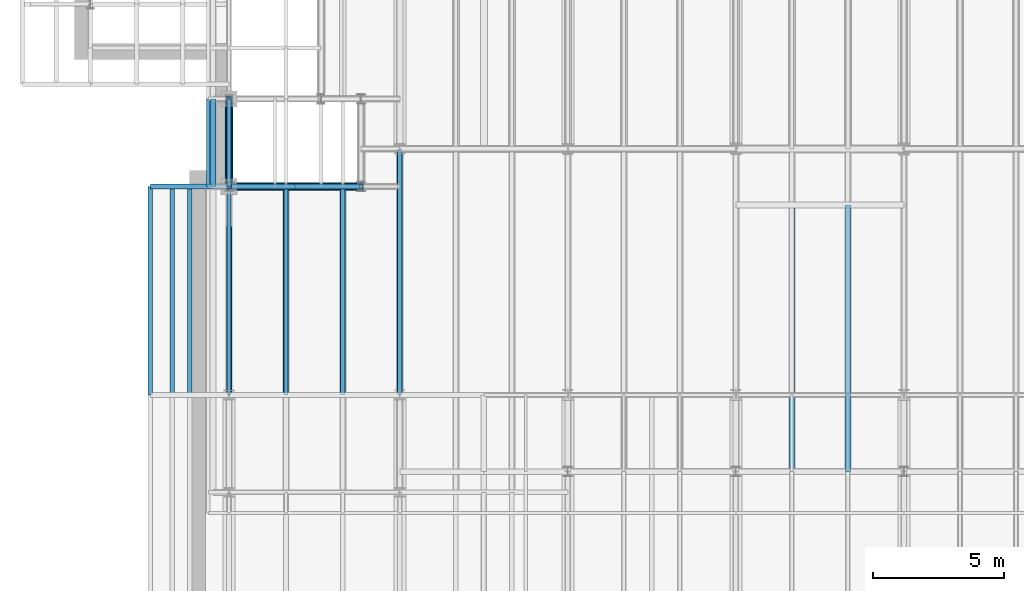
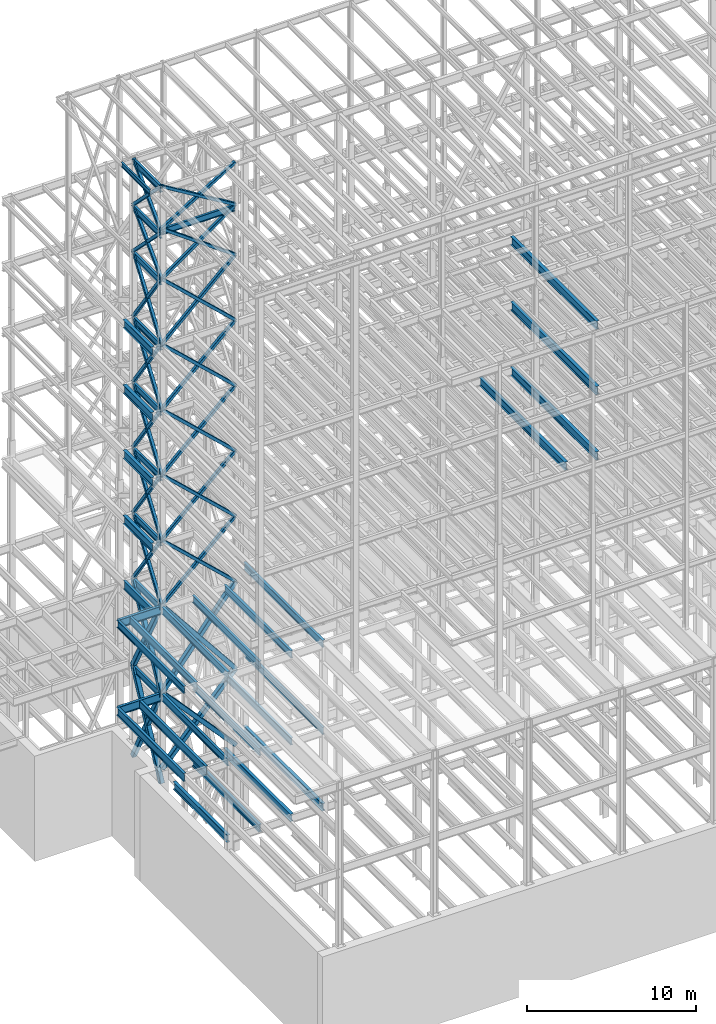
# One storey, part 124 of 150: 74 beams.
"""IFC2X3 building model written with IfcOpenShell, lengths in millimetres."""

from ifc_helpers import new_model, si_unit, frame, origin_with_axes, origin_2d_with_axis, place, context, subcontext, project, spatial, hollow_rectangle, i_section, extrude, material, type_object, element, save


model = new_model("IFC2X3")

# Units and contexts
model_context = context("Model", 3, precision=1e-05, world=origin_with_axes())
body_context = subcontext(model_context, "Body", "Model", "MODEL_VIEW")
ifc_project = project(units=[si_unit("LENGTHUNIT", "METRE", prefix="MILLI"), si_unit("AREAUNIT", "SQUARE_METRE"), si_unit("VOLUMEUNIT", "CUBIC_METRE"), si_unit("MASSUNIT", "GRAM", prefix="KILO"), si_unit("TIMEUNIT", "SECOND"), si_unit("PLANEANGLEUNIT", "RADIAN"), si_unit("SOLIDANGLEUNIT", "STERADIAN"), si_unit("THERMODYNAMICTEMPERATUREUNIT", "DEGREE_CELSIUS"), si_unit("LUMINOUSINTENSITYUNIT", "LUMEN")], contexts=[model_context])

# Site, building, storey
site_placement = place(None, origin_with_axes())
site = spatial("IfcSite", under=ifc_project, at=site_placement, CompositionType="ELEMENT")
building_placement = place(site_placement, origin_with_axes())
building = spatial("IfcBuilding", under=site, at=building_placement, Name="Undefined", CompositionType="ELEMENT")
storey_placement = place(building_placement, origin_with_axes())
storey = spatial("IfcBuildingStorey", under=building, at=storey_placement, Name="Undefined", CompositionType="ELEMENT", Elevation=0.0)

# Beams
ifc_material_1 = material()
beam_type_1 = type_object("IfcBeamType", Name="HSS8X8X3/8", PredefinedType="NOTDEFINED")
beam_1_placement = place(storey_placement, frame((10312.3992353852, 21043.9001130334, 62839.59932357), z_axis=(0.521450134847236, 0.0, 0.853281757022731), x_axis=(-0.853281757022731, 0.0, 0.521450134847236)))
element("IfcBeam", 1, at=beam_1_placement, inside=storey, type_object=beam_type_1, material=ifc_material_1, Name="BEAM", ObjectType="HSS8X8X3/8", context=body_context, shape_type="SweptSolid", body=[
    extrude(hollow_rectangle(XDim=203.2, YDim=203.2, WallThickness=9.525, InnerFilletRadius=9.5249, OuterFilletRadius=19.0499, at=origin_2d_with_axis()), frame((5893.94915716689, 0.0, 0.0), z_axis=(-1.0, 0.0, 0.0), x_axis=(0.0, -1.0, 0.0)), (0.0, 0.0, 1.0), 5893.94915716689),
])
beam_2_placement = place(storey_placement, frame((5283.2, 21043.9, 62839.6), z_axis=(-0.521450017543864, 0.0, 0.853281828708138), x_axis=(0.853281828708139, 0.0, 0.521450017543863)))
element("IfcBeam", 2, at=beam_2_placement, inside=storey, type_object=beam_type_1, material=ifc_material_1, Name="BEAM", ObjectType="HSS8X8X3/8", context=body_context, shape_type="SweptSolid", body=[
    extrude(hollow_rectangle(XDim=203.2, YDim=203.2, WallThickness=9.525, InnerFilletRadius=9.5249, OuterFilletRadius=19.0499, at=origin_2d_with_axis()), frame((5893.94902774016, 0.0, -3.27179895828209e-13), z_axis=(-1.0, 0.0, 0.0), x_axis=(0.0, -1.0, 0.0)), (0.0, 0.0, 1.0), 5893.94902774016),
])
beam_3_placement = place(storey_placement, frame((10312.3992353852, 21043.9001130334, 59207.39932357), z_axis=(0.585490645122251, 0.0, 0.810679162476951), x_axis=(-0.81067916247695, 0.0, 0.585490645122252)))
element("IfcBeam", 3, at=beam_3_placement, inside=storey, type_object=beam_type_1, material=ifc_material_1, Name="BEAM", ObjectType="HSS8X8X3/8", context=body_context, shape_type="SweptSolid", body=[
    extrude(hollow_rectangle(XDim=203.2, YDim=203.2, WallThickness=9.525, InnerFilletRadius=9.5249, OuterFilletRadius=19.0499, at=origin_2d_with_axis()), frame((6203.68654134889, 3.63797880709171e-12, 6.88747563576274e-13), z_axis=(-1.0, 0.0, 0.0), x_axis=(0.0, -1.0, 0.0)), (0.0, 0.0, 1.0), 6203.68654134889),
])
beam_4_placement = place(storey_placement, frame((5283.2, 21043.9, 59207.4), z_axis=(-0.585490531937664, 0.0, 0.810679244221382), x_axis=(0.810679244221382, 0.0, 0.585490531937663)))
element("IfcBeam", 4, at=beam_4_placement, inside=storey, type_object=beam_type_1, material=ifc_material_1, Name="BEAM", ObjectType="HSS8X8X3/8", context=body_context, shape_type="SweptSolid", body=[
    extrude(hollow_rectangle(XDim=203.2, YDim=203.2, WallThickness=9.525, InnerFilletRadius=9.5249, OuterFilletRadius=19.0499, at=origin_2d_with_axis()), frame((6203.68635746518, 0.0, 0.0), z_axis=(-1.0, 0.0, 0.0), x_axis=(0.0, -1.0, 0.0)), (0.0, 0.0, 1.0), 6203.68635746518),
])
beam_5_placement = place(storey_placement, frame((10312.3992353852, 21043.9001130334, 54482.99932357), z_axis=(0.684675567907954, 0.0, 0.728847972289092), x_axis=(-0.728847972289091, 0.0, 0.684675567907954)))
element("IfcBeam", 5, at=beam_5_placement, inside=storey, type_object=beam_type_1, material=ifc_material_1, Name="BEAM", ObjectType="HSS8X8X3/8", context=body_context, shape_type="SweptSolid", body=[
    extrude(hollow_rectangle(XDim=203.2, YDim=203.2, WallThickness=9.525, InnerFilletRadius=9.5249, OuterFilletRadius=19.0499, at=origin_2d_with_axis()), frame((6900.20338110779, 0.0, 7.66076466830223e-13), z_axis=(-1.0, 0.0, 0.0), x_axis=(0.0, -1.0, 0.0)), (0.0, 0.0, 1.0), 6900.20338110779),
])
beam_6_placement = place(storey_placement, frame((5283.2, 21043.9, 54483.0), z_axis=(-0.684675464883562, 0.0, 0.728848069069596), x_axis=(0.728848069069596, 0.0, 0.684675464883561)))
element("IfcBeam", 6, at=beam_6_placement, inside=storey, type_object=beam_type_1, material=ifc_material_1, Name="BEAM", ObjectType="HSS8X8X3/8", context=body_context, shape_type="SweptSolid", body=[
    extrude(hollow_rectangle(XDim=203.2, YDim=203.2, WallThickness=9.525, InnerFilletRadius=9.5249, OuterFilletRadius=19.0499, at=origin_2d_with_axis()), frame((6900.20310870845, 0.0, 0.0), z_axis=(-1.0, 0.0, 0.0), x_axis=(0.0, -1.0, 0.0)), (0.0, 0.0, 1.0), 6900.20310870845),
])
beam_7_placement = place(storey_placement, frame((10312.39949708, 21043.9001130334, 40309.8), z_axis=(0.684675567907954, 0.0, 0.728847972289092), x_axis=(-0.728847972289091, 0.0, 0.684675567907954)))
element("IfcBeam", 7, at=beam_7_placement, inside=storey, type_object=beam_type_1, material=ifc_material_1, Name="BEAM", ObjectType="HSS8X8X3/8", context=body_context, shape_type="SweptSolid", body=[
    extrude(hollow_rectangle(XDim=203.2, YDim=203.2, WallThickness=9.525, InnerFilletRadius=9.5249, OuterFilletRadius=19.0499, at=origin_2d_with_axis()), frame((6900.20310870845, 0.0, 0.0), z_axis=(-1.0, 0.0, 0.0), x_axis=(0.0, -1.0, 0.0)), (0.0, 0.0, 1.0), 6900.20310870844),
])
beam_8_placement = place(storey_placement, frame((5283.2, 21043.9, 40309.8), z_axis=(-0.684675464883562, 0.0, 0.728848069069596), x_axis=(0.728848069069596, 0.0, 0.684675464883561)))
element("IfcBeam", 8, at=beam_8_placement, inside=storey, type_object=beam_type_1, material=ifc_material_1, Name="BEAM", ObjectType="HSS8X8X3/8", context=body_context, shape_type="SweptSolid", body=[
    extrude(hollow_rectangle(XDim=203.2, YDim=203.2, WallThickness=9.525, InnerFilletRadius=9.5249, OuterFilletRadius=19.0499, at=origin_2d_with_axis()), frame((6900.20310870845, 0.0, 0.0), z_axis=(-1.0, 0.0, 0.0), x_axis=(0.0, -1.0, 0.0)), (0.0, 0.0, 1.0), 6900.20308523769),
])
for number, where, z_axis, x_axis, name in (
    (9, (10312.39949708, 21043.9001130334, 35585.4), (0.684675567907954, 0.0, 0.728847972289092), (-0.728847972289091, 0.0, 0.684675567907954), "BEAM"),
    (10, (5283.2, 21043.9, 35585.4), (-0.684675464883562, 0.0, 0.728848069069596), (0.728848069069596, 0.0, 0.684675464883561), "BEAM"),
):
    element("IfcBeam", number, at=place(storey_placement, frame(where, z_axis=z_axis, x_axis=x_axis)), inside=storey, type_object=beam_type_1, material=ifc_material_1, Name=name, ObjectType="HSS8X8X3/8", context=body_context, shape_type="SweptSolid", body=[
        extrude(hollow_rectangle(XDim=203.2, YDim=203.2, WallThickness=9.525, InnerFilletRadius=9.5249, OuterFilletRadius=19.0499, at=origin_2d_with_axis()), frame((6900.20310870845, 0.0, 0.0), z_axis=(-1.0, 0.0, 0.0), x_axis=(0.0, -1.0, 0.0)), (0.0, 0.0, 1.0), 6900.20310870845),
    ])
beam_9_placement = place(storey_placement, frame((5283.2, 24383.9997539549, 62560.1996954019), z_axis=(0.0, 0.708447258296166, 0.705763758075353), x_axis=(0.0, -0.705763758075351, 0.708447258296168)))
element("IfcBeam", 11, at=beam_9_placement, inside=storey, type_object=beam_type_1, material=ifc_material_1, Name="BEAM", ObjectType="HSS8X8X3/8", context=body_context, shape_type="SweptSolid", body=[
    extrude(hollow_rectangle(XDim=203.2, YDim=203.2, WallThickness=9.525, InnerFilletRadius=9.5249, OuterFilletRadius=19.0499, at=origin_2d_with_axis()), frame((4732.60349596287, 0.0, 0.0), z_axis=(-1.0, 0.0, 0.0), x_axis=(0.0, -1.0, 0.0)), (0.0, 0.0, 1.0), 4732.60353810488),
])
beam_10_placement = place(storey_placement, frame((5283.2, 21043.9002460451, 62560.1996954019), z_axis=(0.0, -0.708447258296166, 0.705763758075353), x_axis=(0.0, 0.705763758075351, 0.708447258296168)))
element("IfcBeam", 12, at=beam_10_placement, inside=storey, type_object=beam_type_1, material=ifc_material_1, Name="BEAM", ObjectType="HSS8X8X3/8", context=body_context, shape_type="SweptSolid", body=[
    extrude(hollow_rectangle(XDim=203.2, YDim=203.2, WallThickness=9.525, InnerFilletRadius=9.5249, OuterFilletRadius=19.0499, at=origin_2d_with_axis()), frame((4732.60282350111, 0.0, 0.0), z_axis=(-1.0, 0.0, 0.0), x_axis=(0.0, -1.0, 0.0)), (0.0, 0.0, 1.0), 4732.6028235011),
])
for number, where, z_axis, x_axis, name in (
    (13, (5283.19999999999, 24384.0, 59207.4), (0.0, 0.708447258296166, 0.705763758075353), (0.0, -0.705763758075351, 0.708447258296168), "BEAM"),
    (14, (5283.2, 21043.9, 59207.4), (0.0, -0.708447258296166, 0.705763758075353), (0.0, 0.705763758075351, 0.708447258296168), "BEAM"),
):
    element("IfcBeam", number, at=place(storey_placement, frame(where, z_axis=z_axis, x_axis=x_axis)), inside=storey, type_object=beam_type_1, material=ifc_material_1, Name=name, ObjectType="HSS8X8X3/8", context=body_context, shape_type="SweptSolid", body=[
        extrude(hollow_rectangle(XDim=203.2, YDim=203.2, WallThickness=9.525, InnerFilletRadius=9.5249, OuterFilletRadius=19.0499, at=origin_2d_with_axis()), frame((4732.60349596287, 0.0, 0.0), z_axis=(-1.0, 0.0, 0.0), x_axis=(0.0, -1.0, 0.0)), (0.0, 0.0, 1.0), 4732.60349596287),
    ])
for number, where, z_axis, x_axis, name in (
    (15, (5283.2, 24384.0, 54483.0), (0.0, 0.816541853949868, 0.577286238141975), (0.0, -0.577286238141973, 0.816541853949869), "BEAM"),
    (16, (5283.2, 21043.9, 54483.0), (0.0, -0.816541853949868, 0.577286238141975), (0.0, 0.577286238141973, 0.816541853949869), "BEAM"),
):
    element("IfcBeam", number, at=place(storey_placement, frame(where, z_axis=z_axis, x_axis=x_axis)), inside=storey, type_object=beam_type_1, material=ifc_material_1, Name=name, ObjectType="HSS8X8X3/8", context=body_context, shape_type="SweptSolid", body=[
        extrude(hollow_rectangle(XDim=203.2, YDim=203.2, WallThickness=9.525, InnerFilletRadius=9.5249, OuterFilletRadius=19.0499, at=origin_2d_with_axis()), frame((5785.86409881878, 0.0, 3.21179976993034e-13), z_axis=(-1.0, 0.0, 0.0), x_axis=(0.0, -1.0, 0.0)), (0.0, 0.0, 1.0), 5785.86409881878),
    ])
for number, where, z_axis, x_axis, name in (
    (17, (5283.19999999999, 24384.0, 40309.8), (0.0, 0.816541853949868, 0.577286238141975), (0.0, -0.577286238141973, 0.816541853949869), "BEAM"),
    (18, (5283.2, 21043.9, 40309.8), (0.0, -0.816541853949868, 0.577286238141975), (0.0, 0.577286238141973, 0.816541853949869), "BEAM"),
):
    element("IfcBeam", number, at=place(storey_placement, frame(where, z_axis=z_axis, x_axis=x_axis)), inside=storey, type_object=beam_type_1, material=ifc_material_1, Name=name, ObjectType="HSS8X8X3/8", context=body_context, shape_type="SweptSolid", body=[
        extrude(hollow_rectangle(XDim=203.2, YDim=203.2, WallThickness=9.525, InnerFilletRadius=9.5249, OuterFilletRadius=19.0499, at=origin_2d_with_axis()), frame((5785.86409881878, 0.0, 3.21179976993034e-13), z_axis=(-1.0, 0.0, 0.0), x_axis=(0.0, -1.0, 0.0)), (0.0, 0.0, 1.0), 5785.86409881877),
    ])
for number, where, z_axis, x_axis, name in (
    (19, (5283.2, 24384.0, 35585.4), (0.0, 0.816541853949868, 0.577286238141975), (0.0, -0.577286238141973, 0.816541853949869), "BEAM"),
    (20, (5283.2, 21043.9, 35585.4), (0.0, -0.816541853949868, 0.577286238141975), (0.0, 0.577286238141973, 0.816541853949869), "BEAM"),
):
    element("IfcBeam", number, at=place(storey_placement, frame(where, z_axis=z_axis, x_axis=x_axis)), inside=storey, type_object=beam_type_1, material=ifc_material_1, Name=name, ObjectType="HSS8X8X3/8", context=body_context, shape_type="SweptSolid", body=[
        extrude(hollow_rectangle(XDim=203.2, YDim=203.2, WallThickness=9.525, InnerFilletRadius=9.5249, OuterFilletRadius=19.0499, at=origin_2d_with_axis()), frame((5785.86409881878, 0.0, 3.21179976993034e-13), z_axis=(-1.0, 0.0, 0.0), x_axis=(0.0, -1.0, 0.0)), (0.0, 0.0, 1.0), 5785.86409881878),
    ])
ifc_material_2 = material(Name="STEEL/A992")
beam_type_2 = type_object("IfcBeamType", Name="W18X35", PredefinedType="NOTDEFINED")
beam_11_placement = place(storey_placement, frame((5283.2, 21043.9, 62614.175), z_axis=(0.0, 0.0, 1.0), x_axis=(1.0, 0.0, 0.0)))
element("IfcBeam", 21, at=beam_11_placement, inside=storey, type_object=beam_type_2, material=ifc_material_2, Name="BEAM", ObjectType="W18X35", context=body_context, shape_type="SweptSolid", body=[
    extrude(i_section(OverallWidth=152.4, OverallDepth=450.85, WebThickness=7.9375, FlangeThickness=10.795, FilletRadius=17.78, at=origin_2d_with_axis()), frame((5029.19949708, 0.0, 0.0), z_axis=(-1.0, 0.0, 0.0), x_axis=(0.0, -1.0, 0.0)), (0.0, 0.0, 1.0), 5029.19949708),
])
for number, where, z_axis, x_axis, name in (
    (22, (5283.2, 21043.9, 62334.775), (0.0, 0.0, 1.0), (0.0, 1.0, 0.0), "BEAM"),
    (23, (5283.2, 21043.9, 65687.575), (0.0, 0.0, 1.0), (0.0, 1.0, 0.0), "BEAM"),
    (24, (5283.2, 21043.9, 58981.975), (0.0, 0.0, 1.0), (0.0, 1.0, 0.0), "BEAM"),
    (25, (5283.2, 21043.9, 54257.575), (0.0, 0.0, 1.0), (0.0, 1.0, 0.0), "BEAM"),
    (26, (5283.2, 21043.9, 49533.175), (0.0, 0.0, 1.0), (0.0, 1.0, 0.0), "BEAM"),
    (27, (5283.2, 21043.9, 44808.775), (0.0, 0.0, 1.0), (0.0, 1.0, 0.0), "BEAM"),
    (28, (5283.2, 21043.9, 40084.375), (0.0, 0.0, 1.0), (0.0, 1.0, 0.0), "BEAM"),
    (29, (5283.2, 21043.9, 29060.775), (0.0, 0.0, 1.0), (0.0, 1.0, 0.0), "BEAM"),
    (30, (5283.2, 21043.9, 35359.975), (0.0, 0.0, 1.0), (0.0, 1.0, 0.0), "BEAM"),
):
    element("IfcBeam", number, at=place(storey_placement, frame(where, z_axis=z_axis, x_axis=x_axis)), inside=storey, type_object=beam_type_2, material=ifc_material_2, Name=name, ObjectType="W18X35", context=body_context, shape_type="SweptSolid", body=[
        extrude(i_section(OverallWidth=152.4, OverallDepth=450.85, WebThickness=7.9375, FlangeThickness=10.795, FilletRadius=17.78, at=origin_2d_with_axis()), frame((3340.1, 0.0, 0.0), z_axis=(-1.0, 0.0, 0.0), x_axis=(0.0, -1.0, 0.0)), (0.0, 0.0, 1.0), 3340.09999999999),
    ])
beam_type_3 = type_object("IfcBeamType", Name="HSS8X8X1/4", PredefinedType="NOTDEFINED")
for number, where, z_axis, x_axis, name in (
    (31, (10312.39949708, 21043.9001130334, 49758.6), (0.684675567907954, 0.0, 0.728847972289092), (-0.728847972289091, 0.0, 0.684675567907954), "BEAM"),
    (32, (5283.2, 21043.9, 49758.6), (-0.684675464883562, 0.0, 0.728848069069596), (0.728848069069596, 0.0, 0.684675464883561), "BEAM"),
    (33, (10312.39949708, 21043.9001130334, 45034.2), (0.684675567907954, 0.0, 0.728847972289092), (-0.728847972289091, 0.0, 0.684675567907954), "BEAM"),
    (34, (5283.2, 21043.9, 45034.2), (-0.684675464883562, 0.0, 0.728848069069596), (0.728848069069596, 0.0, 0.684675464883561), "BEAM"),
):
    element("IfcBeam", number, at=place(storey_placement, frame(where, z_axis=z_axis, x_axis=x_axis)), inside=storey, type_object=beam_type_3, material=ifc_material_1, Name=name, ObjectType="HSS8X8X1/4", context=body_context, shape_type="SweptSolid", body=[
        extrude(hollow_rectangle(XDim=203.2, YDim=203.2, WallThickness=6.35, InnerFilletRadius=6.3499, OuterFilletRadius=12.6999, at=origin_2d_with_axis()), frame((6900.20310870845, 0.0, 0.0), z_axis=(-1.0, 0.0, 0.0), x_axis=(0.0, -1.0, 0.0)), (0.0, 0.0, 1.0), 6900.20310870845),
    ])
beam_12_placement = place(storey_placement, frame((5283.19999999999, 24384.0, 49758.6), z_axis=(0.0, 0.816541853949868, 0.577286238141975), x_axis=(0.0, -0.577286238141973, 0.816541853949869)))
element("IfcBeam", 35, at=beam_12_placement, inside=storey, type_object=beam_type_3, material=ifc_material_1, Name="BEAM", ObjectType="HSS8X8X1/4", context=body_context, shape_type="SweptSolid", body=[
    extrude(hollow_rectangle(XDim=203.2, YDim=203.2, WallThickness=6.35, InnerFilletRadius=6.3499, OuterFilletRadius=12.6999, at=origin_2d_with_axis()), frame((5785.86409881878, 0.0, 3.21179976993034e-13), z_axis=(-1.0, 0.0, 0.0), x_axis=(0.0, -1.0, 0.0)), (0.0, 0.0, 1.0), 5785.86409881878),
])
beam_13_placement = place(storey_placement, frame((5283.2, 21043.9005006753, 49758.5998858065), z_axis=(0.0, -0.816541853949868, 0.577286238141975), x_axis=(0.0, 0.577286238141973, 0.816541853949869)))
element("IfcBeam", 36, at=beam_13_placement, inside=storey, type_object=beam_type_3, material=ifc_material_1, Name="BEAM", ObjectType="HSS8X8X1/4", context=body_context, shape_type="SweptSolid", body=[
    extrude(hollow_rectangle(XDim=203.2, YDim=203.2, WallThickness=6.35, InnerFilletRadius=6.3499, OuterFilletRadius=12.6999, at=origin_2d_with_axis()), frame((5785.86390302957, 0.0, 0.0), z_axis=(-1.0, 0.0, 0.0), x_axis=(0.0, -1.0, 0.0)), (0.0, 0.0, 1.0), 5785.86390302957),
])
beam_14_placement = place(storey_placement, frame((5283.2, 24384.0, 45034.2), z_axis=(0.0, 0.816541853949868, 0.577286238141975), x_axis=(0.0, -0.577286238141973, 0.816541853949869)))
element("IfcBeam", 37, at=beam_14_placement, inside=storey, type_object=beam_type_3, material=ifc_material_1, Name="BEAM", ObjectType="HSS8X8X1/4", context=body_context, shape_type="SweptSolid", body=[
    extrude(hollow_rectangle(XDim=203.2, YDim=203.2, WallThickness=6.35, InnerFilletRadius=6.3499, OuterFilletRadius=12.6999, at=origin_2d_with_axis()), frame((5785.86409881878, 0.0, 3.21179976993034e-13), z_axis=(-1.0, 0.0, 0.0), x_axis=(0.0, -1.0, 0.0)), (0.0, 0.0, 1.0), 5785.86409881877),
])
beam_15_placement = place(storey_placement, frame((5283.2, 21043.9, 45034.2), z_axis=(0.0, -0.816541853949868, 0.577286238141975), x_axis=(0.0, 0.577286238141973, 0.816541853949869)))
element("IfcBeam", 38, at=beam_15_placement, inside=storey, type_object=beam_type_3, material=ifc_material_1, Name="BEAM", ObjectType="HSS8X8X1/4", context=body_context, shape_type="SweptSolid", body=[
    extrude(hollow_rectangle(XDim=203.2, YDim=203.2, WallThickness=6.35, InnerFilletRadius=6.3499, OuterFilletRadius=12.6999, at=origin_2d_with_axis()), frame((5785.86409881878, 0.0, 3.21179976993034e-13), z_axis=(-1.0, 0.0, 0.0), x_axis=(0.0, -1.0, 0.0)), (0.0, 0.0, 1.0), 5785.86409881878),
])
beam_type_4 = type_object("IfcBeamType", Name="HSS12X12X5/8", PredefinedType="NOTDEFINED")
beam_16_placement = place(storey_placement, frame((10312.39949708, 21043.9001130334, 29286.2), z_axis=(0.781483328742918, 0.0, 0.623926122947973), x_axis=(-0.623926122947972, 0.0, 0.781483328742918)))
element("IfcBeam", 39, at=beam_16_placement, inside=storey, type_object=beam_type_4, material=ifc_material_1, Name="BEAM", ObjectType="HSS12X12X5/8", context=body_context, shape_type="SweptSolid", body=[
    extrude(hollow_rectangle(XDim=304.8, YDim=304.8, WallThickness=15.875, InnerFilletRadius=15.875, OuterFilletRadius=31.75, at=origin_2d_with_axis()), frame((8060.56872816241, 0.0, -3.63797880709171e-12), z_axis=(-1.0, 0.0, 0.0), x_axis=(0.0, -1.0, 0.0)), (0.0, 0.0, 1.0), 8060.56872816241),
])
beam_17_placement = place(storey_placement, frame((5283.2, 21043.9, 29286.2), z_axis=(-0.781483289814531, 0.0, 0.623926171706763), x_axis=(0.623926171706763, 0.0, 0.781483289814532)))
element("IfcBeam", 40, at=beam_17_placement, inside=storey, type_object=beam_type_4, material=ifc_material_1, Name="BEAM", ObjectType="HSS12X12X5/8", context=body_context, shape_type="SweptSolid", body=[
    extrude(hollow_rectangle(XDim=304.8, YDim=304.8, WallThickness=15.875, InnerFilletRadius=15.875, OuterFilletRadius=31.75, at=origin_2d_with_axis()), frame((8060.56854043871, 0.0, -4.47451439258212e-13), z_axis=(-1.0, 0.0, 0.0), x_axis=(0.0, -1.0, 0.0)), (0.0, 0.0, 1.0), 8060.56854043871),
])
beam_18_placement = place(storey_placement, frame((10312.39949708, 21043.9001130334, 23774.4), z_axis=(0.738706564756254, 0.0, 0.674027159086348), x_axis=(-0.674027159086349, 0.0, 0.738706564756254)))
element("IfcBeam", 41, at=beam_18_placement, inside=storey, type_object=beam_type_4, material=ifc_material_1, Name="BEAM", ObjectType="HSS12X12X5/8", context=body_context, shape_type="SweptSolid", body=[
    extrude(hollow_rectangle(XDim=304.8, YDim=304.8, WallThickness=15.875, InnerFilletRadius=15.875, OuterFilletRadius=31.75, at=origin_2d_with_axis()), frame((7461.41989311885, 0.0, 0.0), z_axis=(-1.0, 0.0, 0.0), x_axis=(0.0, -1.0, 0.0)), (0.0, 0.0, 1.0), 7461.41989311885),
])
beam_19_placement = place(storey_placement, frame((5283.2, 21043.9, 23774.4), z_axis=(-0.738706564756254, 0.0, 0.674027159086348), x_axis=(0.674027159086349, 0.0, 0.738706564756254)))
element("IfcBeam", 42, at=beam_19_placement, inside=storey, type_object=beam_type_4, material=ifc_material_1, Name="BEAM", ObjectType="HSS12X12X5/8", context=body_context, shape_type="SweptSolid", body=[
    extrude(hollow_rectangle(XDim=304.8, YDim=304.8, WallThickness=15.875, InnerFilletRadius=15.875, OuterFilletRadius=31.75, at=origin_2d_with_axis()), frame((7461.41947376477, 0.0, 0.0), z_axis=(-1.0, 0.0, 0.0), x_axis=(0.0, -1.0, 0.0)), (0.0, 0.0, 1.0), 7461.41947376477),
])
beam_20_placement = place(storey_placement, frame((5283.2, 24384.0, 29286.2), z_axis=(0.0, 0.883484433084898, 0.468460517543001), x_axis=(0.0, -0.468460517543001, 0.883484433084898)))
element("IfcBeam", 43, at=beam_20_placement, inside=storey, type_object=beam_type_4, material=ifc_material_1, Name="BEAM", ObjectType="HSS12X12X5/8", context=body_context, shape_type="SweptSolid", body=[
    extrude(hollow_rectangle(XDim=304.8, YDim=304.8, WallThickness=15.875, InnerFilletRadius=15.875, OuterFilletRadius=31.75, at=origin_2d_with_axis()), frame((7129.95011553376, 0.0, 0.0), z_axis=(-1.0, 0.0, 0.0), x_axis=(0.0, -1.0, 0.0)), (0.0, 0.0, 1.0), 7129.95011553377),
])
beam_21_placement = place(storey_placement, frame((5283.2, 21043.9, 29286.2), z_axis=(0.0, -0.883484433084898, 0.468460517543001), x_axis=(0.0, 0.468460517543001, 0.883484433084898)))
element("IfcBeam", 44, at=beam_21_placement, inside=storey, type_object=beam_type_4, material=ifc_material_1, Name="BEAM", ObjectType="HSS12X12X5/8", context=body_context, shape_type="SweptSolid", body=[
    extrude(hollow_rectangle(XDim=304.8, YDim=304.8, WallThickness=15.875, InnerFilletRadius=15.875, OuterFilletRadius=31.75, at=origin_2d_with_axis()), frame((7129.95011553376, 0.0, 0.0), z_axis=(-1.0, 0.0, 0.0), x_axis=(0.0, -1.0, 0.0)), (0.0, 0.0, 1.0), 7129.95011553376),
])
for number, where, z_axis, x_axis, name in (
    (45, (5283.2, 24384.0, 22707.6), (0.0, 0.891656069158826, 0.452713435113461), (0.0, -0.45271343511346, 0.891656069158827), "BEAM"),
    (46, (5283.2, 21043.9, 22707.6), (0.0, -0.891656069158826, 0.452713435113461), (0.0, 0.452713435113461, 0.891656069158827), "BEAM"),
):
    element("IfcBeam", number, at=place(storey_placement, frame(where, z_axis=z_axis, x_axis=x_axis)), inside=storey, type_object=beam_type_4, material=ifc_material_1, Name=name, ObjectType="HSS12X12X5/8", context=body_context, shape_type="SweptSolid", body=[
        extrude(hollow_rectangle(XDim=304.8, YDim=304.8, WallThickness=15.875, InnerFilletRadius=15.875, OuterFilletRadius=31.75, at=origin_2d_with_axis()), frame((7377.95676119073, 0.0, -4.0955887354814e-13), z_axis=(-1.0, 0.0, 0.0), x_axis=(0.0, -1.0, 0.0)), (0.0, 0.0, 1.0), 7377.95676119073),
    ])
beam_type_5 = type_object("IfcBeamType", Name="W24X68", PredefinedType="NOTDEFINED")
beam_22_placement = place(storey_placement, frame((28854.4, 10185.4, 54181.375), z_axis=(0.0, 0.0, 1.0), x_axis=(0.0, 1.0, 0.0)))
element("IfcBeam", 47, at=beam_22_placement, inside=storey, type_object=beam_type_5, material=ifc_material_2, Name="BEAM", ObjectType="W24X68", context=body_context, shape_type="SweptSolid", body=[
    extrude(i_section(OverallWidth=227.838, OverallDepth=603.25, WebThickness=11.1125, FlangeThickness=14.859, FilletRadius=23.2409, at=origin_2d_with_axis()), frame((10160.0, 0.0, 0.0), z_axis=(-1.0, 0.0, 0.0), x_axis=(0.0, -1.0, 0.0)), (0.0, 0.0, 1.0), 10160.0),
])
beam_23_placement = place(storey_placement, frame((4673.6, 21043.9, 54181.375), z_axis=(0.0, 0.0, 1.0), x_axis=(0.0, 1.0, 0.0)))
element("IfcBeam", 48, at=beam_23_placement, inside=storey, type_object=beam_type_5, material=ifc_material_2, Name="BEAM", ObjectType="W24X68", context=body_context, shape_type="SweptSolid", body=[
    extrude(i_section(OverallWidth=227.838, OverallDepth=603.25, WebThickness=11.1125, FlangeThickness=14.859, FilletRadius=23.2409, at=origin_2d_with_axis()), frame((3340.1, 0.0, 0.0), z_axis=(-1.0, 0.0, 0.0), x_axis=(0.0, -1.0, 0.0)), (0.0, 0.0, 1.0), 3340.09999999999),
])
beam_24_placement = place(storey_placement, frame((28854.4, 10185.4, 49456.975), z_axis=(0.0, 0.0, 1.0), x_axis=(0.0, 1.0, 0.0)))
element("IfcBeam", 49, at=beam_24_placement, inside=storey, type_object=beam_type_5, material=ifc_material_2, Name="BEAM", ObjectType="W24X68", context=body_context, shape_type="SweptSolid", body=[
    extrude(i_section(OverallWidth=227.838, OverallDepth=603.25, WebThickness=11.1125, FlangeThickness=14.859, FilletRadius=23.2409, at=origin_2d_with_axis()), frame((10160.0, 0.0, 0.0), z_axis=(-1.0, 0.0, 0.0), x_axis=(0.0, -1.0, 0.0)), (0.0, 0.0, 1.0), 10160.0),
])
beam_25_placement = place(storey_placement, frame((4673.6, 21043.9, 49456.975), z_axis=(0.0, 0.0, 1.0), x_axis=(0.0, 1.0, 0.0)))
element("IfcBeam", 50, at=beam_25_placement, inside=storey, type_object=beam_type_5, material=ifc_material_2, Name="BEAM", ObjectType="W24X68", context=body_context, shape_type="SweptSolid", body=[
    extrude(i_section(OverallWidth=227.838, OverallDepth=603.25, WebThickness=11.1125, FlangeThickness=14.859, FilletRadius=23.2409, at=origin_2d_with_axis()), frame((3340.1, 0.0, 0.0), z_axis=(-1.0, 0.0, 0.0), x_axis=(0.0, -1.0, 0.0)), (0.0, 0.0, 1.0), 3340.09999999999),
])
for number, where, z_axis, x_axis, name in (
    (51, (28854.4, 10185.4, 44732.575), (0.0, 0.0, 1.0), (0.0, 1.0, 0.0), "BEAM"),
    (52, (26720.8, 10185.4, 44732.575), (0.0, 0.0, 1.0), (0.0, 1.0, 0.0), "BEAM"),
):
    element("IfcBeam", number, at=place(storey_placement, frame(where, z_axis=z_axis, x_axis=x_axis)), inside=storey, type_object=beam_type_5, material=ifc_material_2, Name=name, ObjectType="W24X68", context=body_context, shape_type="SweptSolid", body=[
        extrude(i_section(OverallWidth=227.838, OverallDepth=603.25, WebThickness=11.1125, FlangeThickness=14.859, FilletRadius=23.2409, at=origin_2d_with_axis()), frame((10160.0, 0.0, 0.0), z_axis=(-1.0, 0.0, 0.0), x_axis=(0.0, -1.0, 0.0)), (0.0, 0.0, 1.0), 10160.0),
    ])
for number, where, z_axis, x_axis, name in (
    (53, (4673.6, 21043.9, 44732.575), (0.0, 0.0, 1.0), (0.0, 1.0, 0.0), "BEAM"),
    (54, (4673.6, 21043.9, 40008.175), (0.0, 0.0, 1.0), (0.0, 1.0, 0.0), "BEAM"),
):
    element("IfcBeam", number, at=place(storey_placement, frame(where, z_axis=z_axis, x_axis=x_axis)), inside=storey, type_object=beam_type_5, material=ifc_material_2, Name=name, ObjectType="W24X68", context=body_context, shape_type="SweptSolid", body=[
        extrude(i_section(OverallWidth=227.838, OverallDepth=603.25, WebThickness=11.1125, FlangeThickness=14.859, FilletRadius=23.2409, at=origin_2d_with_axis()), frame((3340.1, 0.0, 0.0), z_axis=(-1.0, 0.0, 0.0), x_axis=(0.0, -1.0, 0.0)), (0.0, 0.0, 1.0), 3340.09999999999),
    ])
beam_type_6 = type_object("IfcBeamType", Name="W14X22", PredefinedType="NOTDEFINED")
beam_26_placement = place(storey_placement, frame((4495.8, 21043.9, 65738.375), z_axis=(0.0, 0.0, 1.0), x_axis=(0.0, 1.0, 0.0)))
element("IfcBeam", 55, at=beam_26_placement, inside=storey, type_object=beam_type_6, material=ifc_material_2, Name="BEAM", ObjectType="W14X22", context=body_context, shape_type="SweptSolid", body=[
    extrude(i_section(OverallWidth=127.0, OverallDepth=349.25, WebThickness=6.3499, FlangeThickness=8.509, FilletRadius=18.4785, at=origin_2d_with_axis()), frame((3340.1, 0.0, 0.0), z_axis=(-1.0, 0.0, 0.0), x_axis=(0.0, -1.0, 0.0)), (0.0, 0.0, 1.0), 3340.1),
])
beam_type_7 = type_object("IfcBeamType", Name="W21X44", PredefinedType="NOTDEFINED")
for number, where, z_axis, x_axis, name in (
    (56, (9618.13333333333, 13106.4, 35323.4625), (0.0, 0.0, 1.0), (0.0, 1.0, 0.0), "BEAM"),
    (57, (7450.66666666666, 13106.4, 35323.4625), (0.0, 0.0, 1.0), (0.0, 1.0, 0.0), "BEAM"),
    (58, (5283.2, 13106.4, 35323.4625), (0.0, 0.0, 1.0), (0.0, 1.0, 0.0), "BEAM"),
    (59, (3115.73333333333, 13106.4, 35323.4625), (0.0, 0.0, 1.0), (0.0, 1.0, 0.0), "BEAM"),
    (60, (2286.0, 13106.4, 35323.4625), (0.0, 0.0, 1.0), (0.0, 1.0, 0.0), "BEAM"),
):
    element("IfcBeam", number, at=place(storey_placement, frame(where, z_axis=z_axis, x_axis=x_axis)), inside=storey, type_object=beam_type_7, material=ifc_material_2, Name=name, ObjectType="W21X44", context=body_context, shape_type="SweptSolid", body=[
        extrude(i_section(OverallWidth=165.1, OverallDepth=523.875, WebThickness=9.5249, FlangeThickness=11.43, FilletRadius=17.145, at=origin_2d_with_axis()), frame((7937.5, 0.0, 0.0), z_axis=(-1.0, 0.0, 0.0), x_axis=(0.0, -1.0, 0.0)), (0.0, 0.0, 1.0), 7937.5),
    ])
beam_27_placement = place(storey_placement, frame((11785.6, 13106.4, 35323.4625), z_axis=(0.0, 0.0, 1.0), x_axis=(0.0, 1.0, 0.0)))
element("IfcBeam", 61, at=beam_27_placement, inside=storey, type_object=beam_type_7, material=ifc_material_2, Name="BEAM", ObjectType="W21X44", context=body_context, shape_type="SweptSolid", body=[
    extrude(i_section(OverallWidth=165.1, OverallDepth=523.875, WebThickness=9.5249, FlangeThickness=11.43, FilletRadius=17.145, at=origin_2d_with_axis()), frame((9372.6, 0.0, 0.0), z_axis=(-1.0, 0.0, 0.0), x_axis=(0.0, -1.0, 0.0)), (0.0, 0.0, 1.0), 9372.6),
])
for number, where, z_axis, x_axis, name in (
    (62, (9618.13289984, 13106.4, 29024.2625), (0.0, 0.0, 1.0), (0.0, 1.0, 0.0), "BEAM"),
    (63, (7450.66644992, 13106.4, 29024.2625), (0.0, 0.0, 1.0), (0.0, 1.0, 0.0), "BEAM"),
    (64, (5283.2, 13106.4, 29024.2625), (0.0, 0.0, 1.0), (0.0, 1.0, 0.0), "BEAM"),
):
    element("IfcBeam", number, at=place(storey_placement, frame(where, z_axis=z_axis, x_axis=x_axis)), inside=storey, type_object=beam_type_7, material=ifc_material_2, Name=name, ObjectType="W21X44", context=body_context, shape_type="SweptSolid", body=[
        extrude(i_section(OverallWidth=165.1, OverallDepth=523.875, WebThickness=9.5249, FlangeThickness=11.43, FilletRadius=17.145, at=origin_2d_with_axis()), frame((7937.5, 0.0, 0.0), z_axis=(-1.0, 0.0, 0.0), x_axis=(0.0, -1.0, 0.0)), (0.0, 0.0, 1.0), 7937.5),
    ])
beam_28_placement = place(storey_placement, frame((11785.6, 13106.4, 29024.2625), z_axis=(0.0, 0.0, 1.0), x_axis=(0.0, 1.0, 0.0)))
element("IfcBeam", 65, at=beam_28_placement, inside=storey, type_object=beam_type_7, material=ifc_material_2, Name="BEAM", ObjectType="W21X44", context=body_context, shape_type="SweptSolid", body=[
    extrude(i_section(OverallWidth=165.1, OverallDepth=523.875, WebThickness=9.5249, FlangeThickness=11.43, FilletRadius=17.145, at=origin_2d_with_axis()), frame((9372.6, 0.0, 0.0), z_axis=(-1.0, 0.0, 0.0), x_axis=(0.0, -1.0, 0.0)), (0.0, 0.0, 1.0), 9372.6),
])
beam_type_8 = type_object("IfcBeamType", Name="W24X62", PredefinedType="NOTDEFINED")
beam_29_placement = place(storey_placement, frame((4673.6, 21043.9, 35283.775), z_axis=(0.0, 0.0, 1.0), x_axis=(0.0, 1.0, 0.0)))
element("IfcBeam", 66, at=beam_29_placement, inside=storey, type_object=beam_type_8, material=ifc_material_2, Name="BEAM", ObjectType="W24X62", context=body_context, shape_type="SweptSolid", body=[
    extrude(i_section(OverallWidth=177.8, OverallDepth=603.25, WebThickness=11.1125, FlangeThickness=14.986, FilletRadius=23.114, at=origin_2d_with_axis()), frame((3340.1, 0.0, 0.0), z_axis=(-1.0, 0.0, 0.0), x_axis=(0.0, -1.0, 0.0)), (0.0, 0.0, 1.0), 3340.1),
])
for number, where, z_axis, x_axis, name in (
    (67, (2286.0, 21043.9, 35283.775), (0.0, 0.0, 1.0), (1.0, 0.0, 0.0), "BEAM"),
    (68, (2286.0, 21043.9, 28984.575), (0.0, 0.0, 1.0), (1.0, 0.0, 0.0), "BEAM"),
):
    element("IfcBeam", number, at=place(storey_placement, frame(where, z_axis=z_axis, x_axis=x_axis)), inside=storey, type_object=beam_type_8, material=ifc_material_2, Name=name, ObjectType="W24X62", context=body_context, shape_type="SweptSolid", body=[
        extrude(i_section(OverallWidth=177.8, OverallDepth=603.25, WebThickness=11.1125, FlangeThickness=14.986, FilletRadius=23.114, at=origin_2d_with_axis()), frame((2997.19995427982, 0.0, 0.0), z_axis=(-1.0, 0.0, 0.0), x_axis=(0.0, -1.0, 0.0)), (0.0, 0.0, 1.0), 2997.2),
    ])
for number, where, z_axis, x_axis, name in (
    (69, (3784.6, 13106.4, 28984.575), (0.0, 0.0, 1.0), (0.0, 1.0, 0.0), "BEAM"),
    (70, (2286.0, 13106.4, 28984.575), (0.0, 0.0, 1.0), (0.0, 1.0, 0.0), "BEAM"),
):
    element("IfcBeam", number, at=place(storey_placement, frame(where, z_axis=z_axis, x_axis=x_axis)), inside=storey, type_object=beam_type_8, material=ifc_material_2, Name=name, ObjectType="W24X62", context=body_context, shape_type="SweptSolid", body=[
        extrude(i_section(OverallWidth=177.8, OverallDepth=603.25, WebThickness=11.1125, FlangeThickness=14.986, FilletRadius=23.114, at=origin_2d_with_axis()), frame((7937.5, 0.0, 0.0), z_axis=(-1.0, 0.0, 0.0), x_axis=(0.0, -1.0, 0.0)), (0.0, 0.0, 1.0), 7937.5),
    ])
beam_type_9 = type_object("IfcBeamType", Name="W21X73", PredefinedType="NOTDEFINED")
beam_30_placement = place(storey_placement, frame((5283.2, 13106.4, 23504.525), z_axis=(0.0, 0.0, 1.0), x_axis=(0.0, 1.0, 0.0)))
element("IfcBeam", 71, at=beam_30_placement, inside=storey, type_object=beam_type_9, material=ifc_material_2, Name="BEAM", ObjectType="W21X73", context=body_context, shape_type="SweptSolid", body=[
    extrude(i_section(OverallWidth=209.55, OverallDepth=539.75, WebThickness=11.1125, FlangeThickness=18.796, FilletRadius=17.7164, at=origin_2d_with_axis()), frame((6413.49935865001, 0.0, 0.0), z_axis=(-1.0, 0.0, 0.0), x_axis=(0.0, -1.0, 0.0)), (0.0, 0.0, 1.0), 6413.49935865001),
])
for number, where, z_axis, x_axis, name in (
    (72, (9618.13333333333, 13106.4, 23504.525), (0.0, 0.0, 1.0), (0.0, 1.0, 0.0), "BEAM"),
    (73, (7450.66666666667, 13106.4, 23504.525), (0.0, 0.0, 1.0), (0.0, 1.0, 0.0), "BEAM"),
):
    element("IfcBeam", number, at=place(storey_placement, frame(where, z_axis=z_axis, x_axis=x_axis)), inside=storey, type_object=beam_type_9, material=ifc_material_2, Name=name, ObjectType="W21X73", context=body_context, shape_type="SweptSolid", body=[
        extrude(i_section(OverallWidth=209.55, OverallDepth=539.75, WebThickness=11.1125, FlangeThickness=18.796, FilletRadius=17.7164, at=origin_2d_with_axis()), frame((7937.5, 0.0, 0.0), z_axis=(-1.0, 0.0, 0.0), x_axis=(0.0, -1.0, 0.0)), (0.0, 0.0, 1.0), 7937.5),
    ])
beam_31_placement = place(storey_placement, frame((11785.6, 13106.4, 23504.525), z_axis=(0.0, 0.0, 1.0), x_axis=(0.0, 1.0, 0.0)))
element("IfcBeam", 74, at=beam_31_placement, inside=storey, type_object=beam_type_9, material=ifc_material_2, Name="BEAM", ObjectType="W21X73", context=body_context, shape_type="SweptSolid", body=[
    extrude(i_section(OverallWidth=209.55, OverallDepth=539.75, WebThickness=11.1125, FlangeThickness=18.796, FilletRadius=17.7164, at=origin_2d_with_axis()), frame((9372.6, 0.0, 0.0), z_axis=(-1.0, 0.0, 0.0), x_axis=(0.0, -1.0, 0.0)), (0.0, 0.0, 1.0), 9372.6),
])

save(model, "model.ifc")
